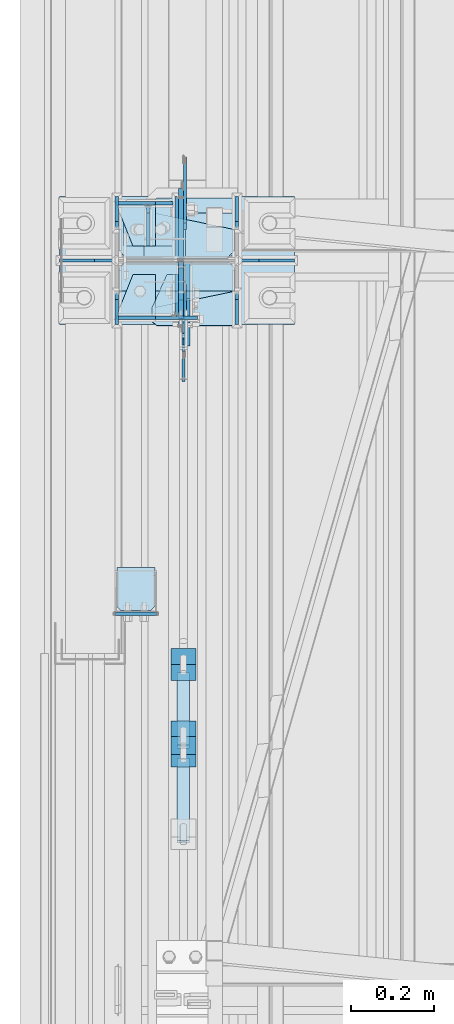
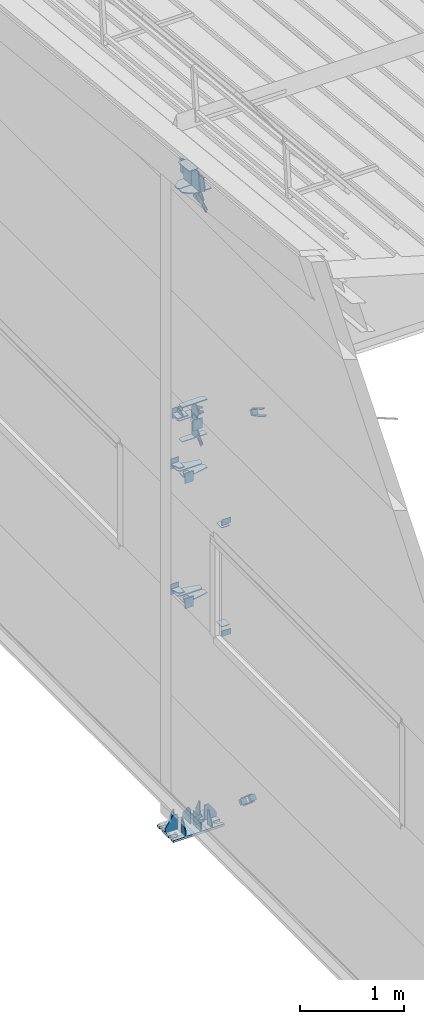
# One storey, part 130 of 709: 54 plates, 4 openings, 17 elements without a shape of their own.
"""IFC4 building model written with IfcOpenShell, lengths in millimetres."""

from ifc_helpers import new_model, si_unit, direction, frame, origin_with_axes, place, context, subcontext, project, spatial, line, arc, indexed_curve, outline, extrude, material, element, aggregate, save


model = new_model("IFC4")

# Units and contexts
model_context = context("Model", 3, precision=0.2, world=origin_with_axes(), true_north=direction((0.0, 1.0)))
body_context = subcontext(model_context, "Body", "Model", "MODEL_VIEW")
ifc_project = project(units=[si_unit("LENGTHUNIT", "METRE", prefix="MILLI"), si_unit("AREAUNIT", "SQUARE_METRE"), si_unit("VOLUMEUNIT", "CUBIC_METRE"), si_unit("MASSUNIT", "GRAM", prefix="KILO"), si_unit("TIMEUNIT", "SECOND"), si_unit("PLANEANGLEUNIT", "RADIAN"), si_unit("SOLIDANGLEUNIT", "STERADIAN"), si_unit("THERMODYNAMICTEMPERATUREUNIT", "DEGREE_CELSIUS"), si_unit("LUMINOUSINTENSITYUNIT", "LUMEN")], contexts=[model_context])

# Site, building, storey
site_placement = place(None, origin_with_axes())
site = spatial("IfcSite", under=ifc_project, at=site_placement, CompositionType="ELEMENT")
building_placement = place(site_placement, origin_with_axes())
building = spatial("IfcBuilding", under=site, at=building_placement, Name="Undefined", CompositionType="ELEMENT")
storey_placement = place(building_placement, origin_with_axes())
storey = spatial("IfcBuildingStorey", under=building, at=storey_placement, Name="Undefined", CompositionType="ELEMENT", Elevation=0.0)

# Assembly, plate
assembly_1_placement = place(storey_placement, frame((162.5, 21654.0, 6929.907), z_axis=(-1.0, 0.0, 0.0), x_axis=(0.0, -0.9950371902, 0.099503719)))
assembly_1 = element("IfcElementAssembly", 1, at=assembly_1_placement, inside=storey)
ifc_material_1 = material(Name="C355-6", Category="STEEL")
plate_1_placement = place(assembly_1_placement, frame((5096.83432, -80.0, -6.5), z_axis=(0.0, 0.0, 1.0), x_axis=(0.0, 1.0, 0.0)))
plate_1 = element("IfcPlate", 2, at=plate_1_placement, material=ifc_material_1, ObjectType="463", context=body_context, shape_type="SolidModel", body=[
    extrude(outline(indexed_curve([(0.0, 0.0), (160.0, 0.0), (160.0, 160.0), (0.0, 160.0)], segments=[line(1, 2, 3, 4, 1)])), frame((0.0, 0.0, 4.0), z_axis=(0.0, 0.0, 1.0), x_axis=(1.0, 0.0, 0.0)), (0.0, 0.0, -1.0), 8.0),
])
aggregate(assembly_1, [plate_1])

assembly_2_placement = place(storey_placement, frame((162.5, 16500.0, 7445.307), z_axis=(-1.0, 0.0, 0.0), x_axis=(0.0, -0.9950371902, 0.099503719)))
assembly_2 = element("IfcElementAssembly", 3, at=assembly_2_placement, inside=storey)
plate_2_placement = place(assembly_2_placement, frame((66.87157, -80.0, -6.5), z_axis=(0.0, 0.0, -1.0), x_axis=(0.0, 1.0, 0.0)))
plate_2 = element("IfcPlate", 4, at=plate_2_placement, material=ifc_material_1, ObjectType="463", context=body_context, shape_type="SolidModel", body=[
    extrude(outline(indexed_curve([(0.0, 0.0), (160.0, 0.0), (160.0, 160.0), (0.0, 160.0)], segments=[line(1, 2, 3, 4, 1)])), frame((0.0, 0.0, 4.0), z_axis=(0.0, 0.0, 1.0), x_axis=(1.0, 0.0, 0.0)), (0.0, 0.0, -1.0), 8.0),
])
aggregate(assembly_2, [plate_2])

# Assembly, plates
assembly_3_placement = place(storey_placement, frame((50.0, 21920.0, 2550.0), z_axis=(0.0, 0.0, -1.0), x_axis=(0.0, -1.0, 0.0)))
assembly_3 = element("IfcElementAssembly", 5, at=assembly_3_placement, inside=storey)
plate_3_placement = place(assembly_3_placement, frame((5285.5, 47.0, 0.0), z_axis=(0.0, 0.0, 1.0), x_axis=(0.0, -1.0, 0.0)))
plate_3 = element("IfcPlate", 6, at=plate_3_placement, material=ifc_material_1, ObjectType="502", context=body_context, shape_type="SolidModel", body=[
    extrude(outline(indexed_curve([(0.0, 0.0), (94.0, 0.0), (94.0, 100.0), (40.0, 100.0), (0.0, 0.0)], segments=[line(1, 2, 3, 4, 5, 1)])), frame((0.0, 0.0, 4.0), z_axis=(0.0, 0.0, 1.0), x_axis=(1.0, 0.0, 0.0)), (0.0, 0.0, -1.0), 8.0),
])
plate_4_placement = place(assembly_3_placement, frame((5281.5, 47.0, -60.0), z_axis=(-1.0, 0.0, 0.0), x_axis=(0.0, -1.0, 0.0)))
plate_4 = element("IfcPlate", 7, at=plate_4_placement, material=ifc_material_1, ObjectType="501", context=body_context, shape_type="SolidModel", body=[
    extrude(outline(indexed_curve([(0.0, 0.0), (94.0, 0.0), (94.0, 120.0), (0.0, 120.0)], segments=[line(1, 2, 3, 4, 1)])), frame((0.0, 0.0, 4.0), z_axis=(0.0, 0.0, 1.0), x_axis=(1.0, 0.0, 0.0)), (0.0, 0.0, -1.0), 8.0),
])
aggregate(assembly_3, [plate_3, plate_4])

assembly_4_placement = place(storey_placement, frame((50.0, 21920.0, 4020.0), z_axis=(0.0, 0.0, -1.0), x_axis=(0.0, -1.0, 0.0)))
assembly_4 = element("IfcElementAssembly", 8, at=assembly_4_placement, inside=storey)
plate_5_placement = place(assembly_4_placement, frame((5281.5, 47.0, -60.0), z_axis=(-1.0, 0.0, 0.0), x_axis=(0.0, -1.0, 0.0)))
plate_5 = element("IfcPlate", 9, at=plate_5_placement, material=ifc_material_1, ObjectType="501", context=body_context, shape_type="SolidModel", body=[
    extrude(outline(indexed_curve([(0.0, 0.0), (94.0, 0.0), (94.0, 120.0), (0.0, 120.0)], segments=[line(1, 2, 3, 4, 1)])), frame((0.0, 0.0, 4.0), z_axis=(0.0, 0.0, 1.0), x_axis=(1.0, 0.0, 0.0)), (0.0, 0.0, -1.0), 8.0),
])
plate_6_placement = place(assembly_4_placement, frame((5285.5, 47.0, 0.0), z_axis=(0.0, 0.0, 1.0), x_axis=(0.0, -1.0, 0.0)))
plate_6 = element("IfcPlate", 10, at=plate_6_placement, material=ifc_material_1, ObjectType="502", context=body_context, shape_type="SolidModel", body=[
    extrude(outline(indexed_curve([(0.0, 0.0), (94.0, 0.0), (94.0, 100.0), (40.0, 100.0), (0.0, 0.0)], segments=[line(1, 2, 3, 4, 5, 1)])), frame((0.0, 0.0, 4.0), z_axis=(0.0, 0.0, 1.0), x_axis=(1.0, 0.0, 0.0)), (0.0, 0.0, -1.0), 8.0),
])
aggregate(assembly_4, [plate_5, plate_6])

assembly_5_placement = place(storey_placement, frame((80.0, 21920.0, 4610.0), z_axis=(0.0, 0.0, -1.0), x_axis=(0.0, -1.0, 0.0)))
assembly_5 = element("IfcElementAssembly", 11, at=assembly_5_placement, inside=storey)
plate_7_placement = place(assembly_5_placement, frame((5385.5, -60.0, 0.0), z_axis=(0.0, 0.0, 1.0), x_axis=(0.0, 1.0, 0.0)))
plate_7 = element("IfcPlate", 12, at=plate_7_placement, material=ifc_material_1, ObjectType="507", context=body_context, shape_type="SolidModel", body=[
    extrude(outline(indexed_curve([(0.0, 0.0), (120.0, 0.0), (120.0, 100.0), (0.0, 100.0)], segments=[line(1, 2, 3, 4, 1)])), frame((0.0, 0.0, 4.0), z_axis=(0.0, 0.0, 1.0), x_axis=(1.0, 0.0, 0.0)), (0.0, 0.0, -1.0), 8.0),
])
plate_8_placement = place(assembly_5_placement, frame((5385.5, 0.0, -60.0), z_axis=(0.0, -1.0, 0.0), x_axis=(0.0, 0.0, 1.0)))
plate_8 = element("IfcPlate", 13, at=plate_8_placement, material=ifc_material_1, ObjectType="508", context=body_context, shape_type="SolidModel", body=[
    extrude(outline(indexed_curve([(0.0, 80.0), (36.0, 0.0), (56.0, 0.0), (56.0, 90.0), (46.0, 100.0), (0.0, 100.0)], segments=[line(1, 2, 3, 4, 5, 6, 1)])), frame((0.0, 0.0, 4.0), z_axis=(0.0, 0.0, 1.0), x_axis=(1.0, 0.0, 0.0)), (0.0, 0.0, -1.0), 8.0),
])
plate_9_placement = place(assembly_5_placement, frame((5281.5, -60.0, 60.0), z_axis=(1.0, 0.0, 0.0), x_axis=(0.0, 0.0, -1.0)))
plate_9 = element("IfcPlate", 14, at=plate_9_placement, material=ifc_material_1, ObjectType="506", context=body_context, shape_type="SolidModel", body=[
    extrude(outline(indexed_curve([(0.0, 0.0), (120.0, 0.0), (120.0, 120.0), (0.0, 120.0)], segments=[line(1, 2, 3, 4, 1)])), frame((0.0, 0.0, 4.0), z_axis=(0.0, 0.0, 1.0), x_axis=(1.0, 0.0, 0.0)), (0.0, 0.0, -1.0), 8.0),
])
aggregate(assembly_5, [plate_7, plate_8, plate_9])

assembly_6_placement = place(storey_placement, frame((50.0, 16500.0, 2550.0), z_axis=(0.0, 0.0, -1.0), x_axis=(0.0, -1.0, 0.0)))
assembly_6 = element("IfcElementAssembly", 15, at=assembly_6_placement, inside=storey)
plate_10_placement = place(assembly_6_placement, frame((138.5, 47.0, -60.0), z_axis=(-1.0, 0.0, 0.0), x_axis=(0.0, -1.0, 0.0)))
plate_10 = element("IfcPlate", 16, at=plate_10_placement, material=ifc_material_1, ObjectType="501", context=body_context, shape_type="SolidModel", body=[
    extrude(outline(indexed_curve([(0.0, 0.0), (94.0, 0.0), (94.0, 120.0), (0.0, 120.0)], segments=[line(1, 2, 3, 4, 1)])), frame((0.0, 0.0, 4.0), z_axis=(0.0, 0.0, 1.0), x_axis=(1.0, 0.0, 0.0)), (0.0, 0.0, -1.0), 8.0),
])
plate_11_placement = place(assembly_6_placement, frame((34.5, 47.0, 0.0), z_axis=(0.0, 0.0, 1.0), x_axis=(0.0, -1.0, 0.0)))
plate_11 = element("IfcPlate", 17, at=plate_11_placement, material=ifc_material_1, ObjectType="502", context=body_context, shape_type="SolidModel", body=[
    extrude(outline(indexed_curve([(0.0, 100.0), (40.0, 0.0), (94.0, 0.0), (94.0, 100.0), (0.0, 100.0)], segments=[line(1, 2, 3, 4, 5, 1)])), frame((0.0, 0.0, 4.0), z_axis=(0.0, 0.0, 1.0), x_axis=(1.0, 0.0, 0.0)), (0.0, 0.0, -1.0), 8.0),
])
plate_12_placement = place(assembly_6_placement, frame((854.0, 50.0, -50.0), z_axis=(-1.0, 0.0, 0.0), x_axis=(0.0, 0.0, -1.0)))
plate_12 = element("IfcPlate", 18, at=plate_12_placement, material=ifc_material_1, ObjectType="509", context=body_context, shape_type="SolidModel", body=[
    extrude(outline(indexed_curve([(0.0, 0.0), (65.0, 0.0), (65.0, 100.0), (0.0, 100.0)], segments=[line(1, 2, 3, 4, 1)])), frame((0.0, 0.0, 4.0), z_axis=(0.0, 0.0, 1.0), x_axis=(1.0, 0.0, 0.0)), (0.0, 0.0, -1.0), 8.0),
])
aggregate(assembly_6, [plate_10, plate_11, plate_12])

assembly_7_placement = place(storey_placement, frame((50.0, 16500.0, 4020.0), z_axis=(0.0, 0.0, -1.0), x_axis=(0.0, -1.0, 0.0)))
assembly_7 = element("IfcElementAssembly", 19, at=assembly_7_placement, inside=storey)
plate_13_placement = place(assembly_7_placement, frame((138.5, 47.0, -60.0), z_axis=(-1.0, 0.0, 0.0), x_axis=(0.0, -1.0, 0.0)))
plate_13 = element("IfcPlate", 20, at=plate_13_placement, material=ifc_material_1, ObjectType="501", context=body_context, shape_type="SolidModel", body=[
    extrude(outline(indexed_curve([(0.0, 0.0), (94.0, 0.0), (94.0, 120.0), (0.0, 120.0)], segments=[line(1, 2, 3, 4, 1)])), frame((0.0, 0.0, 4.0), z_axis=(0.0, 0.0, 1.0), x_axis=(1.0, 0.0, 0.0)), (0.0, 0.0, -1.0), 8.0),
])
plate_14_placement = place(assembly_7_placement, frame((34.5, 47.0, 0.0), z_axis=(0.0, 0.0, 1.0), x_axis=(0.0, -1.0, 0.0)))
plate_14 = element("IfcPlate", 21, at=plate_14_placement, material=ifc_material_1, ObjectType="502", context=body_context, shape_type="SolidModel", body=[
    extrude(outline(indexed_curve([(0.0, 100.0), (40.0, 0.0), (94.0, 0.0), (94.0, 100.0), (0.0, 100.0)], segments=[line(1, 2, 3, 4, 5, 1)])), frame((0.0, 0.0, 4.0), z_axis=(0.0, 0.0, 1.0), x_axis=(1.0, 0.0, 0.0)), (0.0, 0.0, -1.0), 8.0),
])
plate_15_placement = place(assembly_7_placement, frame((854.0, -50.0, 50.0), z_axis=(-1.0, 0.0, 0.0), x_axis=(0.0, 0.0, 1.0)))
plate_15 = element("IfcPlate", 22, at=plate_15_placement, material=ifc_material_1, ObjectType="509", context=body_context, shape_type="SolidModel", body=[
    extrude(outline(indexed_curve([(0.0, 0.0), (65.0, 0.0), (65.0, 100.0), (0.0, 100.0)], segments=[line(1, 2, 3, 4, 1)])), frame((0.0, 0.0, 4.0), z_axis=(0.0, 0.0, 1.0), x_axis=(1.0, 0.0, 0.0)), (0.0, 0.0, -1.0), 8.0),
])
aggregate(assembly_7, [plate_13, plate_14, plate_15])

assembly_8_placement = place(storey_placement, frame((50.0, 15700.0, 2600.0), z_axis=(0.0, -1.0, 0.0), x_axis=(0.0, 0.0, 1.0)))
assembly_8 = element("IfcElementAssembly", 23, at=assembly_8_placement, inside=storey)
plate_16_placement = place(assembly_8_placement, frame((1267.0, 46.0, 46.0), z_axis=(1.0, 0.0, 0.0), x_axis=(0.0, -1.0, 0.0)))
plate_16 = element("IfcPlate", 24, at=plate_16_placement, material=ifc_material_1, ObjectType="510", context=body_context, shape_type="SolidModel", body=[
    extrude(outline(indexed_curve([(0.0, 10.0), (10.0, 0.0), (82.0, 0.0), (92.0, 10.0), (92.0, 104.0), (0.0, 104.0)], segments=[line(1, 2, 3, 4, 5, 6, 1)])), frame((0.0, 0.0, 4.0), z_axis=(0.0, 0.0, 1.0), x_axis=(1.0, 0.0, 0.0)), (0.0, 0.0, -1.0), 8.0),
])
plate_17_placement = place(assembly_8_placement, frame((103.0, -46.0, 46.0), z_axis=(-1.0, 0.0, 0.0), x_axis=(0.0, 1.0, 0.0)))
plate_17 = element("IfcPlate", 25, at=plate_17_placement, material=ifc_material_1, ObjectType="510", context=body_context, shape_type="SolidModel", body=[
    extrude(outline(indexed_curve([(0.0, 10.0), (10.0, 0.0), (82.0, 0.0), (92.0, 10.0), (92.0, 104.0), (0.0, 104.0)], segments=[line(1, 2, 3, 4, 5, 6, 1)])), frame((0.0, 0.0, 4.0), z_axis=(0.0, 0.0, 1.0), x_axis=(1.0, 0.0, 0.0)), (0.0, 0.0, -1.0), 8.0),
])
aggregate(assembly_8, [plate_16, plate_17])

assembly_9_placement = place(storey_placement, frame((149.0, 16500.0, 4610.0), z_axis=(0.0, 0.0, -1.0), x_axis=(0.0, -1.0, 0.0)))
assembly_9 = element("IfcElementAssembly", 26, at=assembly_9_placement, inside=storey)
plate_18_placement = place(assembly_9_placement, frame((138.5, -50.0, 60.0), z_axis=(-1.0, 0.0, 0.0), x_axis=(0.0, 1.0, 0.0)))
plate_18 = element("IfcPlate", 27, at=plate_18_placement, material=ifc_material_1, ObjectType="519", context=body_context, shape_type="SolidModel", body=[
    extrude(outline(indexed_curve([(0.0, 0.0), (110.0, 0.0), (110.0, 120.0), (0.0, 120.0)], segments=[line(1, 2, 3, 4, 1)])), frame((0.0, 0.0, 4.0), z_axis=(0.0, 0.0, 1.0), x_axis=(1.0, 0.0, 0.0)), (0.0, 0.0, -1.0), 8.0),
])
plate_19_placement = place(assembly_9_placement, frame((34.5, 0.0, 60.0), z_axis=(0.0, -1.0, 0.0), x_axis=(0.0, 0.0, -1.0)))
plate_19 = element("IfcPlate", 28, at=plate_19_placement, material=ifc_material_1, ObjectType="520", context=body_context, shape_type="SolidModel", body=[
    extrude(outline(indexed_curve([(0.0, 0.0), (120.0, 0.0), (120.0, 100.0), (0.0, 100.0)], segments=[line(1, 2, 3, 4, 1)])), frame((0.0, 0.0, 4.0), z_axis=(0.0, 0.0, 1.0), x_axis=(1.0, 0.0, 0.0)), (0.0, 0.0, -1.0), 8.0),
])
plate_20_placement = place(assembly_9_placement, frame((34.5, 60.0, 0.0), z_axis=(0.0, 0.0, 1.0), x_axis=(0.0, -1.0, 0.0)))
plate_20 = element("IfcPlate", 29, at=plate_20_placement, material=ifc_material_1, ObjectType="521", context=body_context, shape_type="SolidModel", body=[
    extrude(outline(indexed_curve([(0.0, 80.0), (36.0, 0.0), (56.0, 0.0), (56.0, 90.0), (46.0, 100.0), (0.0, 100.0)], segments=[line(1, 2, 3, 4, 5, 6, 1)])), frame((0.0, 0.0, 4.0), z_axis=(0.0, 0.0, 1.0), x_axis=(1.0, 0.0, 0.0)), (0.0, 0.0, -1.0), 8.0),
])
aggregate(assembly_9, [plate_18, plate_19, plate_20])

# Assembly, plate
assembly_10_placement = place(storey_placement, frame((165.0, 16500.0, -155.0), z_axis=(-1.0, 0.0, 0.0), x_axis=(0.0, -0.7603239329, 0.649544084)))
assembly_10 = element("IfcElementAssembly", 30, at=assembly_10_placement, inside=storey)
plate_21_placement = place(assembly_10_placement, frame((259.82193, 11.0, 0.0), z_axis=(0.0, 0.0, -1.0), x_axis=(-1.0, 0.0, 0.0)))
plate_21 = element("IfcPlate", 31, at=plate_21_placement, material=ifc_material_1, ObjectType="490", context=body_context, shape_type="SolidModel", body=[
    extrude(outline(indexed_curve([(0.0, 0.0), (80.0, 0.0), (80.0, -22.0), (0.0, -22.0), (0.0, -46.0), (200.0, -46.0), (200.0, 24.0), (0.0, 24.0)], segments=[line(1, 2, 3, 4, 5, 6, 7, 8, 1)])), frame((0.0, 0.0, 4.0), z_axis=(0.0, 0.0, 1.0), x_axis=(1.0, 0.0, 0.0)), (0.0, 0.0, -1.0), 8.0),
])
aggregate(assembly_10, [plate_21])

# Assembly, plates
assembly_11_placement = place(storey_placement, frame((135.0, 15367.59556, 851.86901), z_axis=(0.0, 0.7603239329, -0.649544084), x_axis=(1.0, 0.0, 0.0)))
assembly_11 = element("IfcElementAssembly", 32, at=assembly_11_placement, inside=storey)
ifc_material_2 = material(Name="Steel_Undefined", Category="STEEL")
plate_22_placement = place(assembly_11_placement, frame((15.0, 66.0, 230.0), z_axis=(0.0, 1.0, 0.0), x_axis=(1.0, 0.0, 0.0)))
plate_22 = element("IfcPlate", 33, at=plate_22_placement, material=ifc_material_2, ObjectType="484", context=body_context, shape_type="SolidModel", body=[
    extrude(outline(indexed_curve([(0.0, 0.0), (30.0, 0.0), (30.0, 230.0), (0.0, 230.0)], segments=[line(1, 2, 3, 4, 1)])), frame((0.0, 0.0, 6.0), z_axis=(0.0, 0.0, 1.0), x_axis=(1.0, 0.0, 0.0)), (0.0, 0.0, -1.0), 12.0),
])
plate_23_placement = place(assembly_11_placement, frame((0.0, 0.0, 230.0), z_axis=(0.0, 0.0, 1.0), x_axis=(1.0, 0.0, 0.0)))
plate_23 = element("IfcPlate", 34, at=plate_23_placement, material=ifc_material_2, ObjectType="483", context=body_context, shape_type="SolidModel", body=[
    extrude(outline(indexed_curve([(0.0, 0.0), (60.0, 0.0), (60.0, 60.0), (0.0, 60.0)], segments=[line(1, 2, 3, 4, 1)])), frame((0.0, 0.0, 25.0), z_axis=(0.0, 0.0, 1.0), x_axis=(1.0, 0.0, 0.0)), (0.0, 0.0, -1.0), 50.0),
])
plate_24_placement = place(assembly_11_placement, frame((15.0, -6.0, 230.0), z_axis=(0.0, 1.0, 0.0), x_axis=(1.0, 0.0, 0.0)))
plate_24 = element("IfcPlate", 35, at=plate_24_placement, material=ifc_material_2, ObjectType="484", context=body_context, shape_type="SolidModel", body=[
    extrude(outline(indexed_curve([(0.0, 0.0), (30.0, 0.0), (30.0, 230.0), (0.0, 230.0)], segments=[line(1, 2, 3, 4, 1)])), frame((0.0, 0.0, 6.0), z_axis=(0.0, 0.0, 1.0), x_axis=(1.0, 0.0, 0.0)), (0.0, 0.0, -1.0), 12.0),
])
plate_25_placement = place(assembly_11_placement, origin_with_axes())
plate_25 = element("IfcPlate", 36, at=plate_25_placement, material=ifc_material_2, ObjectType="482", context=body_context, shape_type="SolidModel", body=[
    extrude(outline(indexed_curve([(0.0, 0.0), (60.0, 0.0), (60.0, 60.0), (0.0, 60.0)], segments=[line(1, 2, 3, 4, 1)])), frame((0.0, 0.0, 25.0), z_axis=(0.0, 0.0, 1.0), x_axis=(1.0, 0.0, 0.0)), (0.0, 0.0, -1.0), 50.0),
])
aggregate(assembly_11, [plate_22, plate_23, plate_24, plate_25])

# Assembly, plate
assembly_12_placement = place(storey_placement, frame((165.0, 16425.5, 4480.0), z_axis=(-1.0, 0.0, 0.0), x_axis=(0.0, -0.7603239329, -0.649544084)))
assembly_12 = element("IfcElementAssembly", 37, at=assembly_12_placement, inside=storey)
plate_26_placement = place(assembly_12_placement, frame((150.0, -35.0, 0.0), z_axis=(0.0, 0.0, -1.0), x_axis=(-1.0, 0.0, 0.0)))
plate_26 = element("IfcPlate", 38, at=plate_26_placement, material=ifc_material_1, ObjectType="525", context=body_context, shape_type="SolidModel", body=[
    extrude(outline(indexed_curve([(0.0, 0.0), (200.0, 0.0), (200.0, 70.0), (0.0, 70.0), (0.0, 46.0), (80.0, 46.0), (80.0, 24.0), (0.0, 24.0)], segments=[line(1, 2, 3, 4, 5, 6, 7, 8, 1)])), frame((0.0, 0.0, 4.0), z_axis=(0.0, 0.0, 1.0), x_axis=(1.0, 0.0, 0.0)), (0.0, 0.0, -1.0), 8.0),
])
aggregate(assembly_12, [plate_26])

assembly_13_placement = place(storey_placement, frame((165.0, 16425.5, 4740.0), z_axis=(-1.0, 0.0, 0.0), x_axis=(0.0, -0.866144648, 0.499793406)))
assembly_13 = element("IfcElementAssembly", 39, at=assembly_13_placement, inside=storey)
plate_27_placement = place(assembly_13_placement, frame((150.0, -35.0, 0.0), z_axis=(0.0, 0.0, -1.0), x_axis=(-1.0, 0.0, 0.0)))
plate_27 = element("IfcPlate", 40, at=plate_27_placement, material=ifc_material_1, ObjectType="525", context=body_context, shape_type="SolidModel", body=[
    extrude(outline(indexed_curve([(0.0, 0.0), (200.0, 0.0), (200.0, 70.0), (0.0, 70.0), (0.0, 46.0), (80.0, 46.0), (80.0, 24.0), (0.0, 24.0)], segments=[line(1, 2, 3, 4, 5, 6, 7, 8, 1)])), frame((0.0, 0.0, 4.0), z_axis=(0.0, 0.0, 1.0), x_axis=(1.0, 0.0, 0.0)), (0.0, 0.0, -1.0), 8.0),
])
aggregate(assembly_13, [plate_27])

# Assembly, plates
assembly_14_placement = place(storey_placement, frame((135.0, 15128.28466, 5523.17135), z_axis=(0.0, 0.866144648, -0.499793406), x_axis=(1.0, 0.0, 0.0)))
assembly_14 = element("IfcElementAssembly", 41, at=assembly_14_placement, inside=storey)
plate_28_placement = place(assembly_14_placement, frame((0.0, 0.0, 230.0), z_axis=(0.0, 0.0, 1.0), x_axis=(1.0, 0.0, 0.0)))
plate_28 = element("IfcPlate", 42, at=plate_28_placement, material=ifc_material_2, ObjectType="483", context=body_context, shape_type="SolidModel", body=[
    extrude(outline(indexed_curve([(0.0, 0.0), (60.0, 0.0), (60.0, 60.0), (0.0, 60.0)], segments=[line(1, 2, 3, 4, 1)])), frame((0.0, 0.0, 25.0), z_axis=(0.0, 0.0, 1.0), x_axis=(1.0, 0.0, 0.0)), (0.0, 0.0, -1.0), 50.0),
])
plate_29_placement = place(assembly_14_placement, frame((15.0, -6.0, 230.0), z_axis=(0.0, 1.0, 0.0), x_axis=(1.0, 0.0, 0.0)))
plate_29 = element("IfcPlate", 43, at=plate_29_placement, material=ifc_material_2, ObjectType="484", context=body_context, shape_type="SolidModel", body=[
    extrude(outline(indexed_curve([(0.0, 0.0), (30.0, 0.0), (30.0, 230.0), (0.0, 230.0)], segments=[line(1, 2, 3, 4, 1)])), frame((0.0, 0.0, 6.0), z_axis=(0.0, 0.0, 1.0), x_axis=(1.0, 0.0, 0.0)), (0.0, 0.0, -1.0), 12.0),
])
plate_30_placement = place(assembly_14_placement, frame((15.0, 66.0, 230.0), z_axis=(0.0, 1.0, 0.0), x_axis=(1.0, 0.0, 0.0)))
plate_30 = element("IfcPlate", 44, at=plate_30_placement, material=ifc_material_2, ObjectType="484", context=body_context, shape_type="SolidModel", body=[
    extrude(outline(indexed_curve([(0.0, 0.0), (30.0, 0.0), (30.0, 230.0), (0.0, 230.0)], segments=[line(1, 2, 3, 4, 1)])), frame((0.0, 0.0, 6.0), z_axis=(0.0, 0.0, 1.0), x_axis=(1.0, 0.0, 0.0)), (0.0, 0.0, -1.0), 12.0),
])
aggregate(assembly_14, [plate_28, plate_29, plate_30])

# Assembly, plate
assembly_15_placement = place(storey_placement, frame((165.0, 16500.0, 7320.68854), z_axis=(-1.0, 0.0, 0.0), x_axis=(0.0, -0.9030466941, -0.429542394)))
assembly_15 = element("IfcElementAssembly", 45, at=assembly_15_placement, inside=storey)
plate_31_placement = place(assembly_15_placement, frame((307.75045, -11.0, 0.0), z_axis=(0.0, 0.0, 1.0), x_axis=(-1.0, 0.0, 0.0)))
plate_31 = element("IfcPlate", 46, at=plate_31_placement, material=ifc_material_1, ObjectType="490", context=body_context, shape_type="SolidModel", body=[
    extrude(outline(indexed_curve([(0.0, 0.0), (80.0, 0.0), (80.0, -22.0), (0.0, -22.0), (0.0, -46.0), (200.0, -46.0), (200.0, 24.0), (0.0, 24.0)], segments=[line(1, 2, 3, 4, 5, 6, 7, 8, 1)])), frame((0.0, 0.0, 4.0), z_axis=(0.0, 0.0, 1.0), x_axis=(1.0, 0.0, 0.0)), (0.0, 0.0, -1.0), 8.0),
])
aggregate(assembly_15, [plate_31])

# Assembly, plates, voiding features
assembly_16_placement = place(storey_placement, frame((149.0, 16500.0, -200.0), z_axis=(0.0, -1.0, 0.0), x_axis=(0.0, 0.0, 1.0)))
assembly_16 = element("IfcElementAssembly", 47, at=assembly_16_placement, inside=storey)
plate_32_placement = place(assembly_16_placement, frame((7472.08802, -26.0, 206.93776), z_axis=(0.0, -1.0, 0.0), x_axis=(-0.9030466941, 0.0, -0.429542394)))
plate_32 = element("IfcPlate", 48, at=plate_32_placement, material=ifc_material_1, ObjectType="527", context=body_context, shape_type="SolidModel", body=[
    extrude(outline(indexed_curve([(0.0, 0.0), (90.0, 0.0), (161.1017, 149.48037), (57.11612, 198.94206), (35.81141, 192.54783), (-37.38595, 71.44202)], segments=[line(1, 2, 3, 4, 5, 6, 1)])), frame((0.0, 0.0, 6.0), z_axis=(0.0, 0.0, 1.0), x_axis=(1.0, 0.0, 0.0)), (0.0, 0.0, -1.0), 12.0),
])
plate_33_placement = place(assembly_16_placement, frame((4607.30822, 140.0, 74.5), z_axis=(-1.0, 0.0, 0.0), x_axis=(0.0, 0.0, -1.0)))
plate_33 = element("IfcPlate", 49, at=plate_33_placement, material=ifc_material_1, ObjectType="524", context=body_context, shape_type="SolidModel", body=[
    extrude(outline(indexed_curve([(0.0, 0.0), (55.75, 0.0), (70.75, 15.0), (70.75, 265.0), (55.75, 280.0), (0.0, 280.0)], segments=[line(1, 2, 3, 4, 5, 6, 1)])), frame((0.0, 0.0, 4.0), z_axis=(0.0, 0.0, 1.0), x_axis=(1.0, 0.0, 0.0)), (0.0, 0.0, -1.0), 8.0),
])
plate_34_placement = place(assembly_16_placement, frame((5009.96618, 140.0, 74.5), z_axis=(-1.0, 0.0, 0.0), x_axis=(0.0, 0.0, -1.0)))
plate_34 = element("IfcPlate", 50, at=plate_34_placement, material=ifc_material_1, ObjectType="523", context=body_context, shape_type="SolidModel", body=[
    extrude(outline(indexed_curve([(0.0, 0.0), (55.75, 0.0), (70.75, 15.0), (70.75, 265.0), (55.75, 280.0), (0.0, 280.0)], segments=[line(1, 2, 3, 4, 5, 6, 1)])), frame((0.0, 0.0, 6.0), z_axis=(0.0, 0.0, 1.0), x_axis=(1.0, 0.0, 0.0)), (0.0, 0.0, -1.0), 12.0),
])
plate_35_placement = place(assembly_16_placement, frame((5003.96618, -10.0, 95.31653), z_axis=(0.0, -1.0, 0.0), x_axis=(-0.866144648, 0.0, 0.499793406)))
plate_35 = element("IfcPlate", 51, at=plate_35_placement, material=ifc_material_1, ObjectType="522", context=body_context, shape_type="SolidModel", body=[
    extrude(outline(indexed_curve([(0.0, 0.0), (90.0, 0.0), (116.96042, 45.34182), (238.22067, 115.3129), (302.30174, 120.83347), (332.35388, 205.66783), (299.59906, 262.43211), (279.10999, 267.92738), (-33.27197, 87.6729), (-38.76724, 67.18383)], segments=[line(1, 2, 3, 4, 5, 6, 7, 8, 9, 10, 1)])), frame((0.0, 0.0, 6.0), z_axis=(0.0, 0.0, 1.0), x_axis=(1.0, 0.0, 0.0)), (0.0, 0.0, -1.0), 12.0),
])
plate_36_placement = place(assembly_16_placement, frame((114.59681, -26.0, 150.74592), z_axis=(0.0, 1.0, 0.0), x_axis=(0.7603239329, 0.0, -0.649544084)))
plate_36 = element("IfcPlate", 52, at=plate_36_placement, material=ifc_material_1, ObjectType="518", context=body_context, shape_type="SolidModel", body=[
    extrude(outline(indexed_curve([(0.0, 0.0), (90.0, 0.0), (148.1582, 68.07709), (39.41213, 160.97876), (18.26411, 159.31706), (-68.1226, 58.19708)], segments=[line(1, 2, 3, 4, 5, 6, 1)])), frame((0.0, 0.0, 6.0), z_axis=(0.0, 0.0, 1.0), x_axis=(1.0, 0.0, 0.0)), (0.0, 0.0, -1.0), 12.0),
])
plate_37_placement = place(assembly_16_placement, frame((4212.0, 140.0, 3.75), z_axis=(1.0, 0.0, 0.0), x_axis=(0.0, 0.0, 1.0)))
plate_37 = element("IfcPlate", 53, at=plate_37_placement, material=ifc_material_1, ObjectType="500", context=body_context, shape_type="SolidModel", body=[
    extrude(outline(indexed_curve([(0.0, 20.0), (20.0, 0.0), (110.75, 0.0), (110.75, 87.0), (70.75, 280.0), (20.0, 280.0), (0.0, 260.0)], segments=[line(1, 2, 3, 4, 5, 6, 7, 1)])), frame((0.0, 0.0, 4.0), z_axis=(0.0, 0.0, 1.0), x_axis=(1.0, 0.0, 0.0)), (0.0, 0.0, -1.0), 8.0),
])
plate_38_placement = place(assembly_16_placement, frame((2742.0, 140.0, 3.75), z_axis=(1.0, 0.0, 0.0), x_axis=(0.0, 0.0, 1.0)))
plate_38 = element("IfcPlate", 54, at=plate_38_placement, material=ifc_material_1, ObjectType="500", context=body_context, shape_type="SolidModel", body=[
    extrude(outline(indexed_curve([(0.0, 20.0), (20.0, 0.0), (110.75, 0.0), (110.75, 87.0), (70.75, 280.0), (20.0, 280.0), (0.0, 260.0)], segments=[line(1, 2, 3, 4, 5, 6, 7, 1)])), frame((0.0, 0.0, 4.0), z_axis=(0.0, 0.0, 1.0), x_axis=(1.0, 0.0, 0.0)), (0.0, 0.0, -1.0), 8.0),
])
plate_39_placement = place(assembly_16_placement, frame((4802.0, -140.0, -114.5), z_axis=(-1.0, 0.0, 0.0), x_axis=(0.0, 0.0, 1.0)))
plate_39 = element("IfcPlate", 55, at=plate_39_placement, material=ifc_material_1, ObjectType="505", context=body_context, shape_type="SolidModel", body=[
    extrude(outline(indexed_curve([(0.0, 0.0), (95.75, 0.0), (110.75, 15.0), (110.75, 265.0), (95.75, 280.0), (0.0, 280.0)], segments=[line(1, 2, 3, 4, 5, 6, 1)])), frame((0.0, 0.0, 4.0), z_axis=(0.0, 0.0, 1.0), x_axis=(1.0, 0.0, 0.0)), (0.0, 0.0, -1.0), 8.0),
])
plate_40_placement = place(assembly_16_placement, frame((4212.0, -140.0, -3.75), z_axis=(1.0, 0.0, 0.0), x_axis=(0.0, 0.0, -1.0)))
plate_40 = element("IfcPlate", 56, at=plate_40_placement, material=ifc_material_1, ObjectType="500", context=body_context, shape_type="SolidModel", body=[
    extrude(outline(indexed_curve([(0.0, 20.0), (20.0, 0.0), (70.75, 0.0), (110.75, 193.0), (110.75, 280.0), (20.0, 280.0), (0.0, 260.0)], segments=[line(1, 2, 3, 4, 5, 6, 7, 1)])), frame((0.0, 0.0, 4.0), z_axis=(0.0, 0.0, 1.0), x_axis=(1.0, 0.0, 0.0)), (0.0, 0.0, -1.0), 8.0),
])
plate_41_placement = place(assembly_16_placement, frame((2742.0, -140.0, -3.75), z_axis=(1.0, 0.0, 0.0), x_axis=(0.0, 0.0, -1.0)))
plate_41 = element("IfcPlate", 57, at=plate_41_placement, material=ifc_material_1, ObjectType="500", context=body_context, shape_type="SolidModel", body=[
    extrude(outline(indexed_curve([(0.0, 20.0), (20.0, 0.0), (70.75, 0.0), (110.75, 193.0), (110.75, 280.0), (20.0, 280.0), (0.0, 260.0)], segments=[line(1, 2, 3, 4, 5, 6, 7, 1)])), frame((0.0, 0.0, 4.0), z_axis=(0.0, 0.0, 1.0), x_axis=(1.0, 0.0, 0.0)), (0.0, 0.0, -1.0), 8.0),
])
plate_42_placement = place(assembly_16_placement, frame((7526.28426, -139.0, -4.34206), z_axis=(0.9950371902, 0.0, -0.099503719), x_axis=(-0.099503719, 0.0, -0.9950371902)))
plate_42 = element("IfcPlate", 58, at=plate_42_placement, material=ifc_material_1, ObjectType="476", context=body_context, shape_type="SolidModel", body=[
    extrude(outline(indexed_curve([(-0.10791, 14.99961), (15.0, 0.0), (146.70786, 0.0), (146.70786, 187.5), (71.5, 278.0), (13.0, 278.0), (-1.89209, 263.00039)], segments=[line(1, 2, 3, 4, 5, 6, 7, 1)])), frame((0.0, 0.0, 6.0), z_axis=(0.0, 0.0, 1.0), x_axis=(1.0, 0.0, 0.0)), (0.0, 0.0, -1.0), 12.0),
])
plate_43_placement = place(assembly_16_placement, frame((7534.16255, -10.0, 4.74007), z_axis=(0.0, 1.0, 0.0), x_axis=(0.099503719, 0.0, 0.9950371902)))
plate_43 = element("IfcPlate", 59, at=plate_43_placement, material=ifc_material_1, ObjectType="475", context=body_context, shape_type="SolidModel", body=[
    extrude(outline(indexed_curve([(0.0, 0.0), (154.50786, 0.0), (151.92076, 222.12903), (19.44323, 222.06948)], segments=[line(1, 2, 3, 4, 1)])), frame((0.0, 0.0, 6.0), z_axis=(0.0, 0.0, 1.0), x_axis=(1.0, 0.0, 0.0)), (0.0, 0.0, -1.0), 12.0),
])
plate_44_placement = place(assembly_16_placement, frame((7527.03327, -139.0, 3.14801), z_axis=(-0.9950371902, 0.0, 0.099503719), x_axis=(0.099503719, 0.0, 0.9950371902)))
plate_44 = element("IfcPlate", 60, at=plate_44_placement, material=ifc_material_1, ObjectType="474", context=body_context, shape_type="SolidModel", body=[
    extrude(outline(indexed_curve([(0.0, 15.0), (15.0, 0.0), (155.50786, 0.0), (155.50786, 187.5), (73.5, 278.0), (15.0, 278.0), (0.0, 263.0)], segments=[line(1, 2, 3, 4, 5, 6, 7, 1)])), frame((0.0, 0.0, 6.0), z_axis=(0.0, 0.0, 1.0), x_axis=(1.0, 0.0, 0.0)), (0.0, 0.0, -1.0), 12.0),
])
plate_45_placement = place(assembly_16_placement, frame((7533.41354, -10.0, -2.75), z_axis=(0.0, -1.0, 0.0), x_axis=(-0.099503719, 0.0, -0.9950371902)))
plate_45 = element("IfcPlate", 61, at=plate_45_placement, material=ifc_material_1, ObjectType="477", context=body_context, shape_type="SolidModel", body=[
    extrude(outline(indexed_curve([(0.0, 0.0), (147.70786, 0.0), (150.29495, 222.12903), (-22.97066, 222.06948)], segments=[line(1, 2, 3, 4, 1)])), frame((0.0, 0.0, 6.0), z_axis=(0.0, 0.0, 1.0), x_axis=(1.0, 0.0, 0.0)), (0.0, 0.0, -1.0), 12.0),
])
plate_46_placement = place(assembly_16_placement, frame((12.5, -284.0, 155.0), z_axis=(1.0, 0.0, 0.0), x_axis=(0.0, 0.0, -1.0)))
plate_46 = element("IfcPlate", 62, at=plate_46_placement, material=ifc_material_1, context=body_context, shape_type="SolidModel", body=[
    extrude(outline(indexed_curve([(0.0, 0.0), (310.0, 0.0), (310.0, 568.0), (0.0, 568.0)], segments=[line(1, 2, 3, 4, 1)])), frame((0.0, 0.0, 12.5), z_axis=(0.0, 0.0, 1.0), x_axis=(1.0, 0.0, 0.0)), (0.0, 0.0, -1.0), 25.0),
])
voiding_feature_1_placement = place(plate_46_placement, frame((40.0, 568.0, 0.0), z_axis=(0.0, 0.0, -1.0), x_axis=(1.0, 0.0, 0.0)))
element("IfcVoidingFeature", 63, at=voiding_feature_1_placement, cuts=plate_46, PredefinedType="HOLE", context=body_context, shape_type="SolidModel", body=[
    extrude(outline(indexed_curve([(0.0, 0.0), (50.0, 0.0), (50.0, 60.0), (42.67767, 77.67767), (25.0, 85.0), (25.0, 85.0), (7.32233, 77.67767), (0.0, 60.0)], segments=[line(1, 2, 3), arc(3, 4, 5), line(5, 6), arc(6, 7, 8), line(8, 1)])), frame((0.0, 0.0, 12.5), z_axis=(0.0, 0.0, 1.0), x_axis=(1.0, 0.0, 0.0)), (0.0, 0.0, -1.0), 25.0),
])
voiding_feature_2_placement = place(plate_46_placement, frame((40.0, 0.0, 0.0), z_axis=(0.0, 0.0, 1.0), x_axis=(1.0, 0.0, 0.0)))
element("IfcVoidingFeature", 64, at=voiding_feature_2_placement, cuts=plate_46, PredefinedType="HOLE", context=body_context, shape_type="SolidModel", body=[
    extrude(outline(indexed_curve([(0.0, 0.0), (50.0, 0.0), (50.0, 60.0), (42.67767, 77.67767), (25.0, 85.0), (25.0, 85.0), (7.32233, 77.67767), (0.0, 60.0)], segments=[line(1, 2, 3), arc(3, 4, 5), line(5, 6), arc(6, 7, 8), line(8, 1)])), frame((0.0, 0.0, 12.5), z_axis=(0.0, 0.0, 1.0), x_axis=(1.0, 0.0, 0.0)), (0.0, 0.0, -1.0), 25.0),
])
voiding_feature_3_placement = place(plate_46_placement, frame((270.0, 568.0, 0.0), z_axis=(0.0, 0.0, 1.0), x_axis=(-1.0, 0.0, 0.0)))
element("IfcVoidingFeature", 65, at=voiding_feature_3_placement, cuts=plate_46, PredefinedType="HOLE", context=body_context, shape_type="SolidModel", body=[
    extrude(outline(indexed_curve([(0.0, 0.0), (50.0, 0.0), (50.0, 60.0), (42.67767, 77.67767), (25.0, 85.0), (25.0, 85.0), (7.32233, 77.67767), (0.0, 60.0)], segments=[line(1, 2, 3), arc(3, 4, 5), line(5, 6), arc(6, 7, 8), line(8, 1)])), frame((0.0, 0.0, 12.5), z_axis=(0.0, 0.0, 1.0), x_axis=(1.0, 0.0, 0.0)), (0.0, 0.0, -1.0), 25.0),
])
voiding_feature_4_placement = place(plate_46_placement, frame((270.0, 0.0, 0.0), z_axis=(0.0, 0.0, -1.0), x_axis=(-1.0, 0.0, 0.0)))
element("IfcVoidingFeature", 66, at=voiding_feature_4_placement, cuts=plate_46, PredefinedType="HOLE", context=body_context, shape_type="SolidModel", body=[
    extrude(outline(indexed_curve([(0.0, 0.0), (50.0, 0.0), (50.0, 60.0), (42.67767, 77.67767), (25.0, 85.0), (25.0, 85.0), (7.32233, 77.67767), (0.0, 60.0)], segments=[line(1, 2, 3), arc(3, 4, 5), line(5, 6), arc(6, 7, 8), line(8, 1)])), frame((0.0, 0.0, 12.5), z_axis=(0.0, 0.0, 1.0), x_axis=(1.0, 0.0, 0.0)), (0.0, 0.0, -1.0), 25.0),
])
plate_47_placement = place(assembly_16_placement, frame((25.0, 0.0, -2.75), z_axis=(0.0, -1.0, 0.0), x_axis=(0.0, 0.0, -1.0)))
plate_47 = element("IfcPlate", 67, at=plate_47_placement, material=ifc_material_1, ObjectType="417", context=body_context, shape_type="SolidModel", body=[
    extrude(outline(indexed_curve([(0.0, 0.0), (152.25, 0.0), (152.25, 50.0), (50.0, 175.0), (0.0, 175.0)], segments=[line(1, 2, 3, 4, 5, 1)])), frame((0.0, 0.0, 4.0), z_axis=(0.0, 0.0, 1.0), x_axis=(1.0, 0.0, 0.0)), (0.0, 0.0, -1.0), 8.0),
])
plate_48_placement = place(assembly_16_placement, frame((25.0, 145.0, -74.5), z_axis=(0.0, -1.0, 0.0), x_axis=(0.0, 0.0, -1.0)))
plate_48 = element("IfcPlate", 68, at=plate_48_placement, material=ifc_material_1, ObjectType="426", context=body_context, shape_type="SolidModel", body=[
    extrude(outline(indexed_curve([(0.0, 0.0), (80.5, 0.0), (80.5, 50.0), (20.0, 175.0), (0.0, 175.0)], segments=[line(1, 2, 3, 4, 5, 1)])), frame((0.0, 0.0, 4.0), z_axis=(0.0, 0.0, 1.0), x_axis=(1.0, 0.0, 0.0)), (0.0, 0.0, -1.0), 8.0),
])
plate_49_placement = place(assembly_16_placement, frame((25.0, 145.0, 74.5), z_axis=(0.0, 1.0, 0.0), x_axis=(0.0, 0.0, 1.0)))
plate_49 = element("IfcPlate", 69, at=plate_49_placement, material=ifc_material_1, ObjectType="426", context=body_context, shape_type="SolidModel", body=[
    extrude(outline(indexed_curve([(0.0, 0.0), (80.5, 0.0), (80.5, 50.0), (20.0, 175.0), (0.0, 175.0)], segments=[line(1, 2, 3, 4, 5, 1)])), frame((0.0, 0.0, 4.0), z_axis=(0.0, 0.0, 1.0), x_axis=(1.0, 0.0, 0.0)), (0.0, 0.0, -1.0), 8.0),
])
plate_50_placement = place(assembly_16_placement, frame((25.0, -145.0, 74.5), z_axis=(0.0, 1.0, 0.0), x_axis=(0.0, 0.0, 1.0)))
plate_50 = element("IfcPlate", 70, at=plate_50_placement, material=ifc_material_1, ObjectType="426", context=body_context, shape_type="SolidModel", body=[
    extrude(outline(indexed_curve([(0.0, 0.0), (80.5, 0.0), (80.5, 50.0), (20.0, 175.0), (0.0, 175.0)], segments=[line(1, 2, 3, 4, 5, 1)])), frame((0.0, 0.0, 4.0), z_axis=(0.0, 0.0, 1.0), x_axis=(1.0, 0.0, 0.0)), (0.0, 0.0, -1.0), 8.0),
])
plate_51_placement = place(assembly_16_placement, frame((25.0, 149.0, 0.0), z_axis=(0.0, 0.0, -1.0), x_axis=(0.0, 1.0, 0.0)))
plate_51 = element("IfcPlate", 71, at=plate_51_placement, material=ifc_material_1, ObjectType="418", context=body_context, shape_type="SolidModel", body=[
    extrude(outline(indexed_curve([(0.0, 0.0), (135.0, 0.0), (135.0, 50.0), (50.0, 175.0), (0.0, 175.0)], segments=[line(1, 2, 3, 4, 5, 1)])), frame((0.0, 0.0, 4.0), z_axis=(0.0, 0.0, 1.0), x_axis=(1.0, 0.0, 0.0)), (0.0, 0.0, -1.0), 8.0),
])
plate_52_placement = place(assembly_16_placement, frame((25.0, -149.0, 0.0), z_axis=(0.0, 0.0, 1.0), x_axis=(0.0, -1.0, 0.0)))
plate_52 = element("IfcPlate", 72, at=plate_52_placement, material=ifc_material_1, ObjectType="418", context=body_context, shape_type="SolidModel", body=[
    extrude(outline(indexed_curve([(0.0, 0.0), (135.0, 0.0), (135.0, 50.0), (50.0, 175.0), (0.0, 175.0)], segments=[line(1, 2, 3, 4, 5, 1)])), frame((0.0, 0.0, 4.0), z_axis=(0.0, 0.0, 1.0), x_axis=(1.0, 0.0, 0.0)), (0.0, 0.0, -1.0), 8.0),
])
plate_53_placement = place(assembly_16_placement, frame((25.0, -145.0, -74.5), z_axis=(0.0, -1.0, 0.0), x_axis=(0.0, 0.0, -1.0)))
plate_53 = element("IfcPlate", 73, at=plate_53_placement, material=ifc_material_1, ObjectType="426", context=body_context, shape_type="SolidModel", body=[
    extrude(outline(indexed_curve([(0.0, 0.0), (80.5, 0.0), (80.5, 50.0), (20.0, 175.0), (0.0, 175.0)], segments=[line(1, 2, 3, 4, 5, 1)])), frame((0.0, 0.0, 4.0), z_axis=(0.0, 0.0, 1.0), x_axis=(1.0, 0.0, 0.0)), (0.0, 0.0, -1.0), 8.0),
])
aggregate(assembly_16, [plate_32, plate_33, plate_34, plate_35, plate_36, plate_37, plate_38, plate_39, plate_40, plate_41, plate_42, plate_43, plate_44, plate_45, plate_46, plate_47, plate_48, plate_49, plate_50, plate_51, plate_52, plate_53])

# Assembly, plate
assembly_17_placement = place(storey_placement, frame((4000.0, 16509.95037, 7677.42918), z_axis=(0.0, -0.9950371902, 0.099503719), x_axis=(-1.0, 0.0, 0.0)))
assembly_17 = element("IfcElementAssembly", 74, at=assembly_17_placement, inside=storey)
plate_54_placement = place(assembly_17_placement, frame((3830.5, 103.90074, -110.0), z_axis=(0.0, -1.0, 0.0), x_axis=(1.0, 0.0, 0.0)))
plate_54 = element("IfcPlate", 75, at=plate_54_placement, material=ifc_material_1, ObjectType="591", context=body_context, shape_type="SolidModel", body=[
    extrude(outline(indexed_curve([(0.0, 0.0), (100.0, 0.0), (100.0, 220.0), (0.0, 220.0)], segments=[line(1, 2, 3, 4, 1)])), frame((0.0, 0.0, 4.0), z_axis=(0.0, 0.0, 1.0), x_axis=(1.0, 0.0, 0.0)), (0.0, 0.0, -1.0), 8.0),
])
aggregate(assembly_17, [plate_54])

save(model, "model.ifc")
